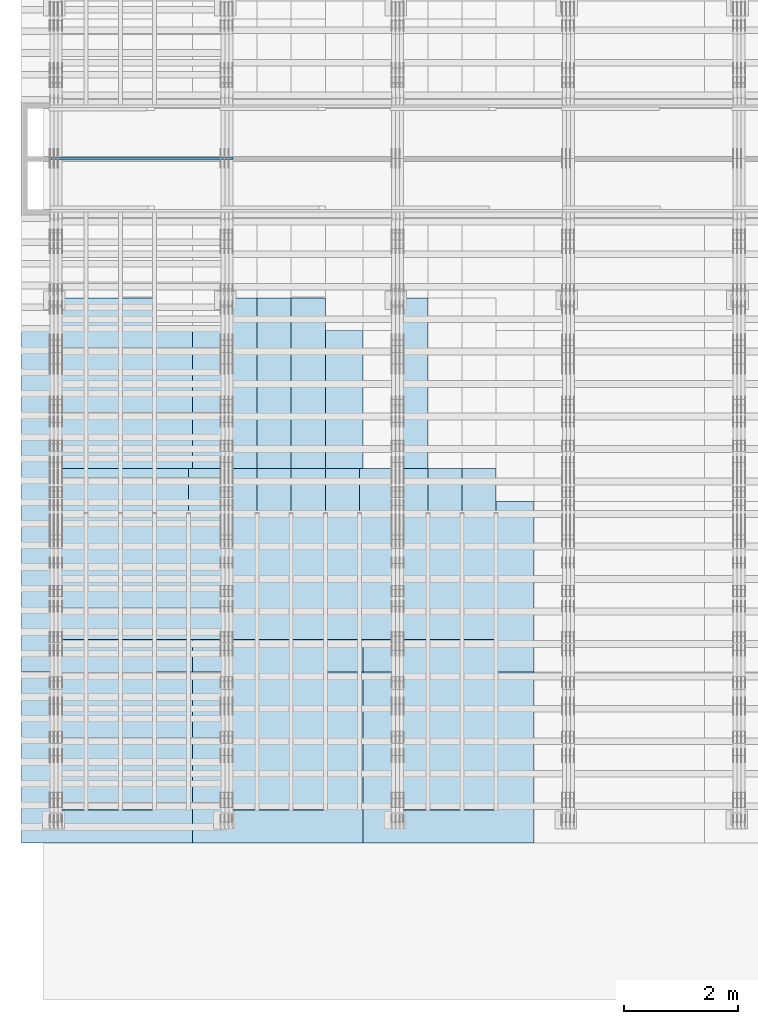
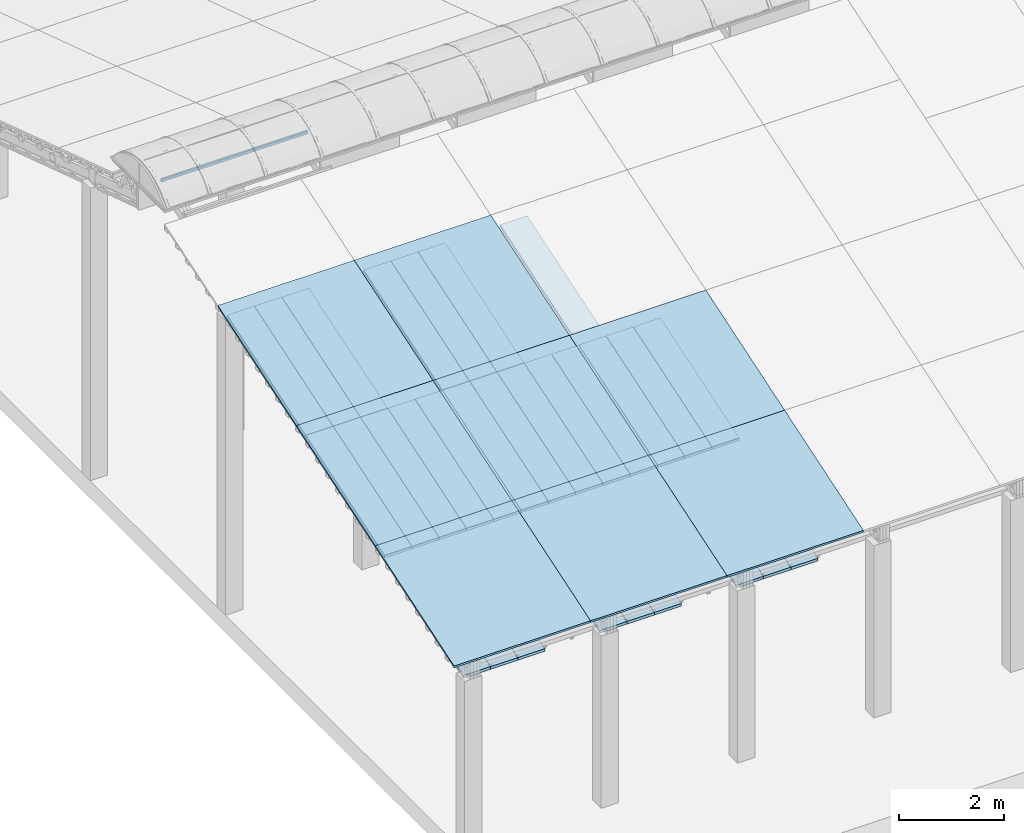
# One storey, part 5 of 385: 37 slabs, 1 column, 37 elements without a shape of their own.
"""IFC2X3 building model written with IfcOpenShell, lengths in millimetres."""

from ifc_helpers import new_model, entity, si_unit, converted_unit, derived_unit, direction, frame, frame_2d, origin, place, context, subcontext, project, spatial, rectangle, extrude, face_set, surface_model, source, transform, mapped, material, layer, layer_set, type_object, type_shapes, element, aggregate, save


model = new_model("IFC2X3")

# Units and contexts
model_context = context("Model", 3, precision=0.01, world=origin(), true_north=direction((6.12303176911189e-17, 1.0)))
body_context = subcontext(model_context, "Body", "Model", "MODEL_VIEW")
ifc_project = project(units=[si_unit("LENGTHUNIT", "METRE", prefix="MILLI"), si_unit("AREAUNIT", "SQUARE_METRE"), si_unit("VOLUMEUNIT", "CUBIC_METRE"), converted_unit("PLANEANGLEUNIT", "DEGREE", entity("IfcRatioMeasure", 0.0174532925199433), si_unit("PLANEANGLEUNIT", "RADIAN"), dimensions=[0, 0, 0, 0, 0, 0, 0]), si_unit("MASSUNIT", "GRAM", prefix="KILO"), derived_unit("MASSDENSITYUNIT", [(si_unit("MASSUNIT", "GRAM", prefix="KILO"), 1), (si_unit("LENGTHUNIT", "METRE"), -3)]), si_unit("TIMEUNIT", "SECOND"), si_unit("FREQUENCYUNIT", "HERTZ"), si_unit("THERMODYNAMICTEMPERATUREUNIT", "DEGREE_CELSIUS"), derived_unit("THERMALTRANSMITTANCEUNIT", [(si_unit("MASSUNIT", "GRAM", prefix="KILO"), 1), (si_unit("THERMODYNAMICTEMPERATUREUNIT", "KELVIN"), -1), (si_unit("TIMEUNIT", "SECOND"), -3)]), derived_unit("VOLUMETRICFLOWRATEUNIT", [(si_unit("LENGTHUNIT", "METRE"), 3), (si_unit("TIMEUNIT", "SECOND"), -1)]), si_unit("ELECTRICCURRENTUNIT", "AMPERE"), si_unit("ELECTRICVOLTAGEUNIT", "VOLT"), si_unit("POWERUNIT", "WATT"), si_unit("FORCEUNIT", "NEWTON", prefix="KILO"), si_unit("ILLUMINANCEUNIT", "LUX"), si_unit("LUMINOUSFLUXUNIT", "LUMEN"), si_unit("LUMINOUSINTENSITYUNIT", "CANDELA"), derived_unit("USERDEFINED", [(si_unit("MASSUNIT", "GRAM", prefix="KILO"), -1), (si_unit("LENGTHUNIT", "METRE"), -2), (si_unit("TIMEUNIT", "SECOND"), 3), (si_unit("LUMINOUSFLUXUNIT", "LUMEN"), 1)]), derived_unit("LINEARVELOCITYUNIT", [(si_unit("LENGTHUNIT", "METRE"), 1), (si_unit("TIMEUNIT", "SECOND"), -1)]), si_unit("PRESSUREUNIT", "PASCAL"), derived_unit("USERDEFINED", [(si_unit("LENGTHUNIT", "METRE"), -2), (si_unit("MASSUNIT", "GRAM", prefix="KILO"), 1), (si_unit("TIMEUNIT", "SECOND"), -2)])], contexts=[model_context])

# Site, building, storey
site_placement = place(None, origin())
site = spatial("IfcSite", under=ifc_project, at=site_placement, CompositionType="ELEMENT")
building_placement = place(site_placement, origin())
building = spatial("IfcBuilding", under=site, at=building_placement, CompositionType="ELEMENT")
storey_placement = place(building_placement, origin())
storey = spatial("IfcBuildingStorey", under=building, at=storey_placement, Name="Default", CompositionType="ELEMENT", Elevation=0.0)

# Column
column_type = type_object("IfcColumnType", Name="70x45", PredefinedType="COLUMN")
shared_shape = source(origin(), body_context, "Body", "SurfaceModel", [
    surface_model("IfcFaceBasedSurfaceModel", [(0.0, 45.0, 4497.55380149334), (0.0, 45.0, 4427.55380149336), (0.0, 0.0, 4427.55380149336), (0.0, 0.0, 4497.55380149334), (3215.2839906129, 45.0, 4497.55380149335), (3215.2839906129, 0.0, 4497.55380149335), (3215.2839906129, 0.0, 4427.55380149337), (3215.2839906129, 45.0, 4427.55380149337)], [face_set([[[0, 1, 2, 3]], [[4, 5, 6, 7]], [[3, 5, 4, 0]], [[2, 3, 5, 6]], [[1, 2, 6, 7]], [[0, 4, 7, 1]]])]),
])
type_shapes(column_type, [shared_shape])
column_placement = place(building_placement, frame((175.0, 14697.5001292288, 0.0)))
element("IfcColumn", 1, at=column_placement, inside=storey, type_object=column_type, Name="H1:70x45", ObjectType="H1:70x45", context=body_context, shape_type="MappedRepresentation", body=[
    mapped(shared_shape, transform((0.0, 0.0, 0.0), scale=1.0)),
])

# Roof, slab
roof_1_placement = place(storey_placement, frame((-325.490958783856, 2697.55668997144, 594.897947736069)))
roof_1 = element("IfcRoof", 2, at=roof_1_placement, inside=storey, ShapeType="NOTDEFINED")
ifc_material_1 = material()
ifc_layer_1 = layer(ifc_material_1, 40.0)
ifc_layer_set_1 = layer_set([ifc_layer_1])
slab_1_placement = place(roof_1_placement, origin())
slab_1 = element("IfcSlab", 3, at=slab_1_placement, material=ifc_layer_set_1, PredefinedType="ROOF", context=body_context, shape_type="SweptSolid", body=[
    extrude(rectangle(XDim=3154.3866727148, YDim=2999.99999999999, at=frame_2d((0.0, 0.0), x_axis=(0.0, -1.0))), frame((1500.0, 1500.0, 487.379544349359), z_axis=(0.0, -0.309016994374947, 0.951056516295154), x_axis=(1.0, 0.0, 0.0)), (0.0, 0.309016994374947, 0.951056516295154), 42.0584889695306),
])
aggregate(roof_1, [slab_1])

roof_2_placement = place(building_placement, frame((-325.490958783852, 5697.55668997145, 1569.65703643478)))
roof_2 = element("IfcRoof", 4, at=roof_2_placement, inside=storey, ShapeType="NOTDEFINED")
slab_2_placement = place(roof_2_placement, origin())
slab_2 = element("IfcSlab", 5, at=slab_2_placement, material=ifc_layer_set_1, PredefinedType="ROOF", context=body_context, shape_type="SweptSolid", body=[
    extrude(rectangle(XDim=3154.3866727148, YDim=2999.99999999999, at=frame_2d((0.0, 1.13686837721616e-13), x_axis=(0.0, -1.0))), frame((1500.0, 1500.0, 487.379544349359), z_axis=(0.0, -0.309016994374947, 0.951056516295154), x_axis=(1.0, 0.0, 0.0)), (0.0, 0.309016994374947, 0.951056516295154), 42.0584889695306),
])
aggregate(roof_2, [slab_2])

roof_3_placement = place(building_placement, frame((-325.490958783847, 8697.55668997145, 2544.4161251335)))
roof_3 = element("IfcRoof", 6, at=roof_3_placement, inside=storey, ShapeType="NOTDEFINED")
slab_3_placement = place(roof_3_placement, origin())
slab_3 = element("IfcSlab", 7, at=slab_3_placement, material=ifc_layer_set_1, PredefinedType="ROOF", context=body_context, shape_type="SweptSolid", body=[
    extrude(rectangle(XDim=3154.3866727148, YDim=2999.99999999999, at=frame_2d((0.0, -1.02318153949454e-12), x_axis=(0.0, -1.0))), frame((1500.0, 1500.0, 487.379544349359), z_axis=(0.0, -0.309016994374947, 0.951056516295154), x_axis=(1.0, 0.0, 0.0)), (0.0, 0.309016994374947, 0.951056516295154), 42.0584889695308),
])
aggregate(roof_3, [slab_3])

roof_4_placement = place(storey_placement, frame((210.0, 3272.33214521007, -186.497271233013)))
roof_4 = element("IfcRoof", 8, at=roof_4_placement, inside=storey, ShapeType="NOTDEFINED")
ifc_material_2 = material(Name="NLRS_n7_isolatie MegaPlus_Kingspan")
ifc_layer_2 = layer(ifc_material_2, 60.0)
ifc_layer_set_2 = layer_set([ifc_layer_2])
slab_4_placement = place(roof_4_placement, origin())
slab_4 = element("IfcSlab", 9, at=slab_4_placement, material=ifc_layer_set_2, PredefinedType="ROOF", context=body_context, shape_type="SweptSolid", body=[
    extrude(rectangle(XDim=600.0, YDim=3154.38667271481, at=frame_2d((-8.5265128291212e-14, 1.25055521493778e-12), x_axis=(-1.0, 0.0))), frame((300.0, 1500.0, 487.379544349361), z_axis=(0.0, -0.309016994374947, 0.951056516295154), x_axis=(1.0, 0.0, 0.0)), (0.0, 0.309016994374947, 0.951056516295154), 63.0877334542961),
])
aggregate(roof_4, [slab_4])

roof_5_placement = place(storey_placement, frame((210.0, 6272.33214521008, 788.261817465711)))
roof_5 = element("IfcRoof", 10, at=roof_5_placement, inside=storey, ShapeType="NOTDEFINED")
slab_5_placement = place(roof_5_placement, origin())
slab_5 = element("IfcSlab", 11, at=slab_5_placement, material=ifc_layer_set_2, PredefinedType="ROOF", context=body_context, shape_type="SweptSolid", body=[
    extrude(rectangle(XDim=600.0, YDim=3154.38667271481, at=frame_2d((0.0, 1.25055521493778e-12), x_axis=(-1.0, 0.0))), frame((300.0, 1500.0, 487.379544349361), z_axis=(0.0, -0.309016994374947, 0.951056516295154), x_axis=(1.0, 0.0, 0.0)), (0.0, 0.309016994374947, 0.951056516295154), 63.0877334542962),
])
aggregate(roof_5, [slab_5])

roof_6_placement = place(storey_placement, frame((210.0, 9272.3321452101, 1763.02090616443)))
roof_6 = element("IfcRoof", 12, at=roof_6_placement, inside=storey, ShapeType="NOTDEFINED")
slab_6_placement = place(roof_6_placement, origin())
slab_6 = element("IfcSlab", 13, at=slab_6_placement, material=ifc_layer_set_2, PredefinedType="ROOF", context=body_context, shape_type="SweptSolid", body=[
    extrude(rectangle(XDim=600.0, YDim=3154.38667271481, at=frame_2d((0.0, 1.13686837721616e-13), x_axis=(-1.0, 0.0))), frame((300.0, 1500.0, 487.379544349361), z_axis=(0.0, -0.309016994374947, 0.951056516295154), x_axis=(1.0, 0.0, 0.0)), (0.0, 0.309016994374947, 0.951056516295154), 63.0877334542962),
])
aggregate(roof_6, [slab_6])

roof_7_placement = place(storey_placement, frame((810.0, 3272.33214521007, -186.497271233012)))
roof_7 = element("IfcRoof", 14, at=roof_7_placement, inside=storey, ShapeType="NOTDEFINED")
slab_7_placement = place(roof_7_placement, origin())
slab_7 = element("IfcSlab", 15, at=slab_7_placement, material=ifc_layer_set_2, PredefinedType="ROOF", context=body_context, shape_type="SweptSolid", body=[
    extrude(rectangle(XDim=600.0, YDim=3154.38667271481, at=frame_2d((5.6843418860808e-14, 0.0), x_axis=(-1.0, 0.0))), frame((300.0, 1500.0, 487.379544349361), z_axis=(0.0, -0.309016994374947, 0.951056516295154), x_axis=(1.0, 0.0, 0.0)), (0.0, 0.309016994374947, 0.951056516295154), 63.087733454296),
])
aggregate(roof_7, [slab_7])

roof_8_placement = place(storey_placement, frame((810.0, 6272.33214521008, 788.261817465712)))
roof_8 = element("IfcRoof", 16, at=roof_8_placement, inside=storey, ShapeType="NOTDEFINED")
slab_8_placement = place(roof_8_placement, origin())
slab_8 = element("IfcSlab", 17, at=slab_8_placement, material=ifc_layer_set_2, PredefinedType="ROOF", context=body_context, shape_type="SweptSolid", body=[
    extrude(rectangle(XDim=600.0, YDim=3154.38667271481, at=frame_2d((0.0, 0.0), x_axis=(-1.0, 0.0))), frame((300.0, 1500.0, 487.379544349361), z_axis=(0.0, -0.309016994374947, 0.951056516295154), x_axis=(1.0, 0.0, 0.0)), (0.0, 0.309016994374947, 0.951056516295154), 63.087733454296),
])
aggregate(roof_8, [slab_8])

roof_9_placement = place(storey_placement, frame((810.0, 9272.33214521009, 1763.02090616443)))
roof_9 = element("IfcRoof", 18, at=roof_9_placement, inside=storey, ShapeType="NOTDEFINED")
slab_9_placement = place(roof_9_placement, origin())
slab_9 = element("IfcSlab", 19, at=slab_9_placement, material=ifc_layer_set_2, PredefinedType="ROOF", context=body_context, shape_type="SweptSolid", body=[
    extrude(rectangle(XDim=600.0, YDim=3154.38667271481, at=frame_2d((0.0, 0.0), x_axis=(-1.0, 0.0))), frame((300.0, 1500.0, 487.379544349361), z_axis=(0.0, -0.309016994374947, 0.951056516295154), x_axis=(1.0, 0.0, 0.0)), (0.0, 0.309016994374947, 0.951056516295154), 63.087733454296),
])
aggregate(roof_9, [slab_9])

roof_10_placement = place(storey_placement, frame((1410.0, 3272.33214521007, -186.497271233013)))
roof_10 = element("IfcRoof", 20, at=roof_10_placement, inside=storey, ShapeType="NOTDEFINED")
slab_10_placement = place(roof_10_placement, origin())
slab_10 = element("IfcSlab", 21, at=slab_10_placement, material=ifc_layer_set_2, PredefinedType="ROOF", context=body_context, shape_type="SweptSolid", body=[
    extrude(rectangle(XDim=600.0, YDim=3154.38667271482, at=frame_2d((0.0, -5.6843418860808e-13), x_axis=(-1.0, 0.0))), frame((300.0, 1500.0, 487.379544349362), z_axis=(0.0, -0.309016994374947, 0.951056516295154), x_axis=(1.0, 0.0, 0.0)), (0.0, 0.309016994374947, 0.951056516295154), 63.087733454296),
])
aggregate(roof_10, [slab_10])

roof_11_placement = place(storey_placement, frame((1410.0, 6272.33214521008, 788.261817465711)))
roof_11 = element("IfcRoof", 22, at=roof_11_placement, inside=storey, ShapeType="NOTDEFINED")
slab_11_placement = place(roof_11_placement, origin())
slab_11 = element("IfcSlab", 23, at=slab_11_placement, material=ifc_layer_set_2, PredefinedType="ROOF", context=body_context, shape_type="SweptSolid", body=[
    extrude(rectangle(XDim=600.0, YDim=3154.38667271482, at=frame_2d((0.0, 0.0), x_axis=(-1.0, 0.0))), frame((300.0, 1500.0, 487.379544349362), z_axis=(0.0, -0.309016994374947, 0.951056516295154), x_axis=(1.0, 0.0, 0.0)), (0.0, 0.309016994374947, 0.951056516295154), 63.087733454296),
])
aggregate(roof_11, [slab_11])

roof_12_placement = place(storey_placement, frame((1410.0, 9272.33214521009, 1763.02090616443)))
roof_12 = element("IfcRoof", 24, at=roof_12_placement, inside=storey, ShapeType="NOTDEFINED")
slab_12_placement = place(roof_12_placement, origin())
slab_12 = element("IfcSlab", 25, at=slab_12_placement, material=ifc_layer_set_2, PredefinedType="ROOF", context=body_context, shape_type="SweptSolid", body=[
    extrude(rectangle(XDim=600.0, YDim=3154.38667271482, at=frame_2d((0.0, 0.0), x_axis=(-1.0, 0.0))), frame((300.0, 1500.0, 487.379544349361), z_axis=(0.0, -0.309016994374947, 0.951056516295154), x_axis=(1.0, 0.0, 0.0)), (0.0, 0.309016994374947, 0.951056516295154), 63.087733454296),
])
aggregate(roof_12, [slab_12])

roof_13_placement = place(storey_placement, frame((3210.0, 3272.33214521006, -186.497271233013)))
roof_13 = element("IfcRoof", 26, at=roof_13_placement, inside=storey, ShapeType="NOTDEFINED")
slab_13_placement = place(roof_13_placement, origin())
slab_13 = element("IfcSlab", 27, at=slab_13_placement, material=ifc_layer_set_2, PredefinedType="ROOF", context=body_context, shape_type="SweptSolid", body=[
    extrude(rectangle(XDim=600.000000000001, YDim=3154.38667271481, at=frame_2d((-2.8421709430404e-13, 1.25055521493778e-12), x_axis=(-1.0, 0.0))), frame((300.0, 1500.0, 487.379544349361), z_axis=(0.0, -0.309016994374947, 0.951056516295154), x_axis=(1.0, 0.0, 0.0)), (0.0, 0.309016994374947, 0.951056516295154), 63.0877334542961),
])
aggregate(roof_13, [slab_13])

roof_14_placement = place(storey_placement, frame((3210.0, 6272.33214521008, 788.261817465711)))
roof_14 = element("IfcRoof", 28, at=roof_14_placement, inside=storey, ShapeType="NOTDEFINED")
slab_14_placement = place(roof_14_placement, origin())
slab_14 = element("IfcSlab", 29, at=slab_14_placement, material=ifc_layer_set_2, PredefinedType="ROOF", context=body_context, shape_type="SweptSolid", body=[
    extrude(rectangle(XDim=600.000000000001, YDim=3154.38667271481, at=frame_2d((2.8421709430404e-13, 1.25055521493778e-12), x_axis=(-1.0, 0.0))), frame((300.0, 1500.0, 487.379544349361), z_axis=(0.0, -0.309016994374947, 0.951056516295154), x_axis=(1.0, 0.0, 0.0)), (0.0, 0.309016994374947, 0.951056516295154), 63.0877334542962),
])
aggregate(roof_14, [slab_14])

roof_15_placement = place(storey_placement, frame((3210.0, 9272.33214521009, 1763.02090616443)))
roof_15 = element("IfcRoof", 30, at=roof_15_placement, inside=storey, ShapeType="NOTDEFINED")
slab_15_placement = place(roof_15_placement, origin())
slab_15 = element("IfcSlab", 31, at=slab_15_placement, material=ifc_layer_set_2, PredefinedType="ROOF", context=body_context, shape_type="SweptSolid", body=[
    extrude(rectangle(XDim=600.0, YDim=3154.38667271481, at=frame_2d((0.0, 1.13686837721616e-13), x_axis=(-1.0, 0.0))), frame((300.0, 1500.0, 487.379544349361), z_axis=(0.0, -0.309016994374947, 0.951056516295154), x_axis=(1.0, 0.0, 0.0)), (0.0, 0.309016994374947, 0.951056516295154), 63.0877334542962),
])
aggregate(roof_15, [slab_15])

roof_16_placement = place(storey_placement, frame((3810.0, 3272.33214521006, -186.497271233012)))
roof_16 = element("IfcRoof", 32, at=roof_16_placement, inside=storey, ShapeType="NOTDEFINED")
slab_16_placement = place(roof_16_placement, origin())
slab_16 = element("IfcSlab", 33, at=slab_16_placement, material=ifc_layer_set_2, PredefinedType="ROOF", context=body_context, shape_type="SweptSolid", body=[
    extrude(rectangle(XDim=600.0, YDim=3154.38667271481, at=frame_2d((-2.55795384873636e-13, 0.0), x_axis=(-1.0, 0.0))), frame((300.0, 1500.0, 487.379544349361), z_axis=(0.0, -0.309016994374947, 0.951056516295154), x_axis=(1.0, 0.0, 0.0)), (0.0, 0.309016994374947, 0.951056516295154), 63.087733454296),
])
aggregate(roof_16, [slab_16])

roof_17_placement = place(storey_placement, frame((3810.0, 6272.33214521007, 788.261817465712)))
roof_17 = element("IfcRoof", 34, at=roof_17_placement, inside=storey, ShapeType="NOTDEFINED")
slab_17_placement = place(roof_17_placement, origin())
slab_17 = element("IfcSlab", 35, at=slab_17_placement, material=ifc_layer_set_2, PredefinedType="ROOF", context=body_context, shape_type="SweptSolid", body=[
    extrude(rectangle(XDim=600.0, YDim=3154.38667271481, at=frame_2d((0.0, 0.0), x_axis=(-1.0, 0.0))), frame((300.0, 1500.0, 487.379544349361), z_axis=(0.0, -0.309016994374947, 0.951056516295154), x_axis=(1.0, 0.0, 0.0)), (0.0, 0.309016994374947, 0.951056516295154), 63.087733454296),
])
aggregate(roof_17, [slab_17])

roof_18_placement = place(storey_placement, frame((3810.0, 9272.33214521008, 1763.02090616443)))
roof_18 = element("IfcRoof", 36, at=roof_18_placement, inside=storey, ShapeType="NOTDEFINED")
slab_18_placement = place(roof_18_placement, origin())
slab_18 = element("IfcSlab", 37, at=slab_18_placement, material=ifc_layer_set_2, PredefinedType="ROOF", context=body_context, shape_type="SweptSolid", body=[
    extrude(rectangle(XDim=600.0, YDim=3154.38667271481, at=frame_2d((0.0, 0.0), x_axis=(-1.0, 0.0))), frame((300.0, 1500.0, 487.379544349361), z_axis=(0.0, -0.309016994374947, 0.951056516295154), x_axis=(1.0, 0.0, 0.0)), (0.0, 0.309016994374947, 0.951056516295154), 63.087733454296),
])
aggregate(roof_18, [slab_18])

roof_19_placement = place(storey_placement, frame((4410.0, 3272.33214521006, -186.497271233013)))
roof_19 = element("IfcRoof", 38, at=roof_19_placement, inside=storey, ShapeType="NOTDEFINED")
slab_19_placement = place(roof_19_placement, origin())
slab_19 = element("IfcSlab", 39, at=slab_19_placement, material=ifc_layer_set_2, PredefinedType="ROOF", context=body_context, shape_type="SweptSolid", body=[
    extrude(rectangle(XDim=600.0, YDim=3154.38667271482, at=frame_2d((0.0, -5.6843418860808e-13), x_axis=(-1.0, 0.0))), frame((300.0, 1500.0, 487.379544349362), z_axis=(0.0, -0.309016994374947, 0.951056516295154), x_axis=(1.0, 0.0, 0.0)), (0.0, 0.309016994374947, 0.951056516295154), 63.087733454296),
])
aggregate(roof_19, [slab_19])

roof_20_placement = place(storey_placement, frame((4410.0, 6272.33214521007, 788.261817465711)))
roof_20 = element("IfcRoof", 40, at=roof_20_placement, inside=storey, ShapeType="NOTDEFINED")
slab_20_placement = place(roof_20_placement, origin())
slab_20 = element("IfcSlab", 41, at=slab_20_placement, material=ifc_layer_set_2, PredefinedType="ROOF", context=body_context, shape_type="SweptSolid", body=[
    extrude(rectangle(XDim=600.0, YDim=3154.38667271482, at=frame_2d((0.0, 0.0), x_axis=(-1.0, 0.0))), frame((300.0, 1500.0, 487.379544349362), z_axis=(0.0, -0.309016994374947, 0.951056516295154), x_axis=(1.0, 0.0, 0.0)), (0.0, 0.309016994374947, 0.951056516295154), 63.087733454296),
])
aggregate(roof_20, [slab_20])

roof_21_placement = place(storey_placement, frame((4410.0, 9272.33214521008, 1763.02090616443)))
roof_21 = element("IfcRoof", 42, at=roof_21_placement, inside=storey, ShapeType="NOTDEFINED")
slab_21_placement = place(roof_21_placement, origin())
slab_21 = element("IfcSlab", 43, at=slab_21_placement, material=ifc_layer_set_2, PredefinedType="ROOF", context=body_context, shape_type="SweptSolid", body=[
    extrude(rectangle(XDim=600.0, YDim=3154.38667271482, at=frame_2d((0.0, 0.0), x_axis=(-1.0, 0.0))), frame((300.0, 1500.0, 487.379544349361), z_axis=(0.0, -0.309016994374947, 0.951056516295154), x_axis=(1.0, 0.0, 0.0)), (0.0, 0.309016994374947, 0.951056516295154), 63.087733454296),
])
aggregate(roof_21, [slab_21])

roof_22_placement = place(storey_placement, frame((6210.0, 3272.33214521006, -186.497271233013)))
roof_22 = element("IfcRoof", 44, at=roof_22_placement, inside=storey, ShapeType="NOTDEFINED")
slab_22_placement = place(roof_22_placement, origin())
slab_22 = element("IfcSlab", 45, at=slab_22_placement, material=ifc_layer_set_2, PredefinedType="ROOF", context=body_context, shape_type="SweptSolid", body=[
    extrude(rectangle(XDim=600.000000000001, YDim=3154.38667271481, at=frame_2d((0.0, 1.25055521493778e-12), x_axis=(-1.0, 0.0))), frame((300.0, 1500.0, 487.379544349361), z_axis=(0.0, -0.309016994374947, 0.951056516295154), x_axis=(1.0, 0.0, 0.0)), (0.0, 0.309016994374947, 0.951056516295154), 63.0877334542961),
])
aggregate(roof_22, [slab_22])

roof_23_placement = place(storey_placement, frame((6210.0, 6272.33214521007, 788.261817465711)))
roof_23 = element("IfcRoof", 46, at=roof_23_placement, inside=storey, ShapeType="NOTDEFINED")
slab_23_placement = place(roof_23_placement, origin())
slab_23 = element("IfcSlab", 47, at=slab_23_placement, material=ifc_layer_set_2, PredefinedType="ROOF", context=body_context, shape_type="SweptSolid", body=[
    extrude(rectangle(XDim=600.000000000001, YDim=3154.38667271481, at=frame_2d((0.0, 1.25055521493778e-12), x_axis=(-1.0, 0.0))), frame((300.0, 1500.0, 487.379544349361), z_axis=(0.0, -0.309016994374947, 0.951056516295154), x_axis=(1.0, 0.0, 0.0)), (0.0, 0.309016994374947, 0.951056516295154), 63.0877334542962),
])
aggregate(roof_23, [slab_23])

roof_24_placement = place(storey_placement, frame((6210.0, 9272.33214521008, 1763.02090616443)))
roof_24 = element("IfcRoof", 48, at=roof_24_placement, inside=storey, ShapeType="NOTDEFINED")
slab_24_placement = place(roof_24_placement, origin())
slab_24 = element("IfcSlab", 49, at=slab_24_placement, material=ifc_layer_set_2, PredefinedType="ROOF", context=body_context, shape_type="SweptSolid", body=[
    extrude(rectangle(XDim=600.000000000001, YDim=3154.38667271481, at=frame_2d((0.0, 1.13686837721616e-13), x_axis=(-1.0, 0.0))), frame((300.0, 1500.0, 487.379544349361), z_axis=(0.0, -0.309016994374947, 0.951056516295154), x_axis=(1.0, 0.0, 0.0)), (0.0, 0.309016994374947, 0.951056516295154), 63.0877334542962),
])
aggregate(roof_24, [slab_24])

roof_25_placement = place(storey_placement, frame((6810.0, 3272.33214521005, -186.497271233012)))
roof_25 = element("IfcRoof", 50, at=roof_25_placement, inside=storey, ShapeType="NOTDEFINED")
slab_25_placement = place(roof_25_placement, origin())
slab_25 = element("IfcSlab", 51, at=slab_25_placement, material=ifc_layer_set_2, PredefinedType="ROOF", context=body_context, shape_type="SweptSolid", body=[
    extrude(rectangle(XDim=600.0, YDim=3154.38667271481, at=frame_2d((5.40012479177676e-13, 0.0), x_axis=(-1.0, 0.0))), frame((300.0, 1500.0, 487.379544349361), z_axis=(0.0, -0.309016994374947, 0.951056516295154), x_axis=(1.0, 0.0, 0.0)), (0.0, 0.309016994374947, 0.951056516295154), 63.087733454296),
])
aggregate(roof_25, [slab_25])

roof_26_placement = place(storey_placement, frame((6810.0, 6272.33214521007, 788.261817465712)))
roof_26 = element("IfcRoof", 52, at=roof_26_placement, inside=storey, ShapeType="NOTDEFINED")
slab_26_placement = place(roof_26_placement, origin())
slab_26 = element("IfcSlab", 53, at=slab_26_placement, material=ifc_layer_set_2, PredefinedType="ROOF", context=body_context, shape_type="SweptSolid", body=[
    extrude(rectangle(XDim=600.0, YDim=3154.38667271481, at=frame_2d((5.40012479177676e-13, 0.0), x_axis=(-1.0, 0.0))), frame((300.0, 1500.0, 487.379544349361), z_axis=(0.0, -0.309016994374947, 0.951056516295154), x_axis=(1.0, 0.0, 0.0)), (0.0, 0.309016994374947, 0.951056516295154), 63.087733454296),
])
aggregate(roof_26, [slab_26])

roof_27_placement = place(storey_placement, frame((7410.0, 3272.33214521005, -186.497271233013)))
roof_27 = element("IfcRoof", 54, at=roof_27_placement, inside=storey, ShapeType="NOTDEFINED")
slab_27_placement = place(roof_27_placement, origin())
slab_27 = element("IfcSlab", 55, at=slab_27_placement, material=ifc_layer_set_2, PredefinedType="ROOF", context=body_context, shape_type="SweptSolid", body=[
    extrude(rectangle(XDim=600.000000000001, YDim=3154.38667271482, at=frame_2d((0.0, -5.6843418860808e-13), x_axis=(-1.0, 0.0))), frame((300.0, 1500.0, 487.379544349362), z_axis=(0.0, -0.309016994374947, 0.951056516295154), x_axis=(1.0, 0.0, 0.0)), (0.0, 0.309016994374947, 0.951056516295154), 63.087733454296),
])
aggregate(roof_27, [slab_27])

roof_28_placement = place(storey_placement, frame((7410.0, 6272.33214521006, 788.261817465711)))
roof_28 = element("IfcRoof", 56, at=roof_28_placement, inside=storey, ShapeType="NOTDEFINED")
slab_28_placement = place(roof_28_placement, origin())
slab_28 = element("IfcSlab", 57, at=slab_28_placement, material=ifc_layer_set_2, PredefinedType="ROOF", context=body_context, shape_type="SweptSolid", body=[
    extrude(rectangle(XDim=600.0, YDim=3154.38667271482, at=frame_2d((5.40012479177676e-13, 0.0), x_axis=(-1.0, 0.0))), frame((300.0, 1500.0, 487.379544349362), z_axis=(0.0, -0.309016994374947, 0.951056516295154), x_axis=(1.0, 0.0, 0.0)), (0.0, 0.309016994374947, 0.951056516295154), 63.087733454296),
])
aggregate(roof_28, [slab_28])

roof_29_placement = place(storey_placement, frame((2674.50904121613, 2697.55668997143, 594.897947736069)))
roof_29 = element("IfcRoof", 58, at=roof_29_placement, inside=storey, ShapeType="NOTDEFINED")
slab_29_placement = place(roof_29_placement, origin())
slab_29 = element("IfcSlab", 59, at=slab_29_placement, material=ifc_layer_set_1, PredefinedType="ROOF", context=body_context, shape_type="SweptSolid", body=[
    extrude(rectangle(XDim=3154.3866727148, YDim=2999.99999999999, at=frame_2d((0.0, 5.6843418860808e-13), x_axis=(0.0, -1.0))), frame((1500.0, 1500.0, 487.379544349359), z_axis=(0.0, -0.309016994374947, 0.951056516295154), x_axis=(1.0, 0.0, 0.0)), (0.0, 0.309016994374947, 0.951056516295154), 42.0584889695306),
])
aggregate(roof_29, [slab_29])

roof_30_placement = place(storey_placement, frame((2674.50904121614, 5697.55668997144, 1569.65703643478)))
roof_30 = element("IfcRoof", 60, at=roof_30_placement, inside=storey, ShapeType="NOTDEFINED")
slab_30_placement = place(roof_30_placement, origin())
slab_30 = element("IfcSlab", 61, at=slab_30_placement, material=ifc_layer_set_1, PredefinedType="ROOF", context=body_context, shape_type="SweptSolid", body=[
    extrude(rectangle(XDim=3154.3866727148, YDim=2999.99999999999, at=frame_2d((0.0, 6.82121026329696e-13), x_axis=(0.0, -1.0))), frame((1500.0, 1500.0, 487.379544349359), z_axis=(0.0, -0.309016994374947, 0.951056516295154), x_axis=(1.0, 0.0, 0.0)), (0.0, 0.309016994374947, 0.951056516295154), 42.0584889695306),
])
aggregate(roof_30, [slab_30])

roof_31_placement = place(storey_placement, frame((2674.50904121614, 8697.55668997144, 2544.4161251335)))
roof_31 = element("IfcRoof", 62, at=roof_31_placement, inside=storey, ShapeType="NOTDEFINED")
slab_31_placement = place(roof_31_placement, origin())
slab_31 = element("IfcSlab", 63, at=slab_31_placement, material=ifc_layer_set_1, PredefinedType="ROOF", context=body_context, shape_type="SweptSolid", body=[
    extrude(rectangle(XDim=3154.3866727148, YDim=2999.99999999999, at=frame_2d((0.0, -3.41060513164848e-13), x_axis=(0.0, -1.0))), frame((1500.0, 1500.0, 487.379544349359), z_axis=(0.0, -0.309016994374947, 0.951056516295154), x_axis=(1.0, 0.0, 0.0)), (0.0, 0.309016994374947, 0.951056516295154), 42.0584889695308),
])
aggregate(roof_31, [slab_31])

roof_32_placement = place(storey_placement, frame((5674.50904121612, 2697.55668997142, 594.897947736069)))
roof_32 = element("IfcRoof", 64, at=roof_32_placement, inside=storey, ShapeType="NOTDEFINED")
slab_32_placement = place(roof_32_placement, origin())
slab_32 = element("IfcSlab", 65, at=slab_32_placement, material=ifc_layer_set_1, PredefinedType="ROOF", context=body_context, shape_type="SweptSolid", body=[
    extrude(rectangle(XDim=3154.3866727148, YDim=2999.99999999999, at=frame_2d((0.0, 0.0), x_axis=(0.0, -1.0))), frame((1500.0, 1500.0, 487.379544349359), z_axis=(0.0, -0.309016994374947, 0.951056516295154), x_axis=(1.0, 0.0, 0.0)), (0.0, 0.309016994374947, 0.951056516295154), 42.0584889695306),
])
aggregate(roof_32, [slab_32])

roof_33_placement = place(storey_placement, frame((5674.50904121614, 5697.55668997143, 1569.65703643478)))
roof_33 = element("IfcRoof", 66, at=roof_33_placement, inside=storey, ShapeType="NOTDEFINED")
slab_33_placement = place(roof_33_placement, origin())
slab_33 = element("IfcSlab", 67, at=slab_33_placement, material=ifc_layer_set_1, PredefinedType="ROOF", context=body_context, shape_type="SweptSolid", body=[
    extrude(rectangle(XDim=3154.3866727148, YDim=2999.99999999999, at=frame_2d((0.0, 1.13686837721616e-13), x_axis=(0.0, -1.0))), frame((1500.0, 1500.0, 487.379544349359), z_axis=(0.0, -0.309016994374947, 0.951056516295154), x_axis=(1.0, 0.0, 0.0)), (0.0, 0.309016994374947, 0.951056516295154), 42.0584889695306),
])
aggregate(roof_33, [slab_33])

roof_34_placement = place(storey_placement, frame((2610.0, 6272.33214521008, 788.261817465713)))
roof_34 = element("IfcRoof", 68, at=roof_34_placement, inside=storey, ShapeType="NOTDEFINED")
slab_34_placement = place(roof_34_placement, origin())
slab_34 = element("IfcSlab", 69, at=slab_34_placement, material=ifc_layer_set_2, PredefinedType="ROOF", context=body_context, shape_type="SweptSolid", body=[
    extrude(rectangle(XDim=600.000000000001, YDim=3154.38667271481, at=frame_2d((2.8421709430404e-13, 1.25055521493778e-12), x_axis=(-1.0, 0.0))), frame((300.0, 1500.0, 487.379544349361), z_axis=(0.0, -0.309016994374947, 0.951056516295154), x_axis=(1.0, 0.0, 0.0)), (0.0, 0.309016994374947, 0.951056516295154), 63.087733454296),
])
aggregate(roof_34, [slab_34])

roof_35_placement = place(storey_placement, frame((2010.0, 6272.33214521008, 788.261817465713)))
roof_35 = element("IfcRoof", 70, at=roof_35_placement, inside=storey, ShapeType="NOTDEFINED")
slab_35_placement = place(roof_35_placement, origin())
slab_35 = element("IfcSlab", 71, at=slab_35_placement, material=ifc_layer_set_2, PredefinedType="ROOF", context=body_context, shape_type="SweptSolid", body=[
    extrude(rectangle(XDim=600.000000000001, YDim=3154.38667271481, at=frame_2d((0.0, 1.25055521493778e-12), x_axis=(-1.0, 0.0))), frame((300.0, 1500.0, 487.379544349361), z_axis=(0.0, -0.309016994374947, 0.951056516295154), x_axis=(1.0, 0.0, 0.0)), (0.0, 0.309016994374947, 0.951056516295154), 63.087733454296),
])
aggregate(roof_35, [slab_35])

roof_36_placement = place(storey_placement, frame((5010.0, 6272.33214521007, 788.261817465709)))
roof_36 = element("IfcRoof", 72, at=roof_36_placement, inside=storey, ShapeType="NOTDEFINED")
slab_36_placement = place(roof_36_placement, origin())
slab_36 = element("IfcSlab", 73, at=slab_36_placement, material=ifc_layer_set_2, PredefinedType="ROOF", context=body_context, shape_type="SweptSolid", body=[
    extrude(rectangle(XDim=599.999999999999, YDim=3154.38667271482, at=frame_2d((0.0, 0.0), x_axis=(-1.0, 0.0))), frame((300.0, 1500.0, 487.379544349362), z_axis=(0.0, -0.309016994374947, 0.951056516295154), x_axis=(1.0, 0.0, 0.0)), (0.0, 0.309016994374947, 0.951056516295154), 63.087733454296),
])
aggregate(roof_36, [slab_36])

roof_37_placement = place(storey_placement, frame((5610.0, 6272.33214521007, 788.261817465709)))
roof_37 = element("IfcRoof", 74, at=roof_37_placement, inside=storey, ShapeType="NOTDEFINED")
slab_37_placement = place(roof_37_placement, origin())
slab_37 = element("IfcSlab", 75, at=slab_37_placement, material=ifc_layer_set_2, PredefinedType="ROOF", context=body_context, shape_type="SweptSolid", body=[
    extrude(rectangle(XDim=599.999999999999, YDim=3154.38667271482, at=frame_2d((0.0, 0.0), x_axis=(-1.0, 0.0))), frame((300.0, 1500.0, 487.379544349362), z_axis=(0.0, -0.309016994374947, 0.951056516295154), x_axis=(1.0, 0.0, 0.0)), (0.0, 0.309016994374947, 0.951056516295154), 63.087733454296),
])
aggregate(roof_37, [slab_37])

save(model, "model.ifc")
